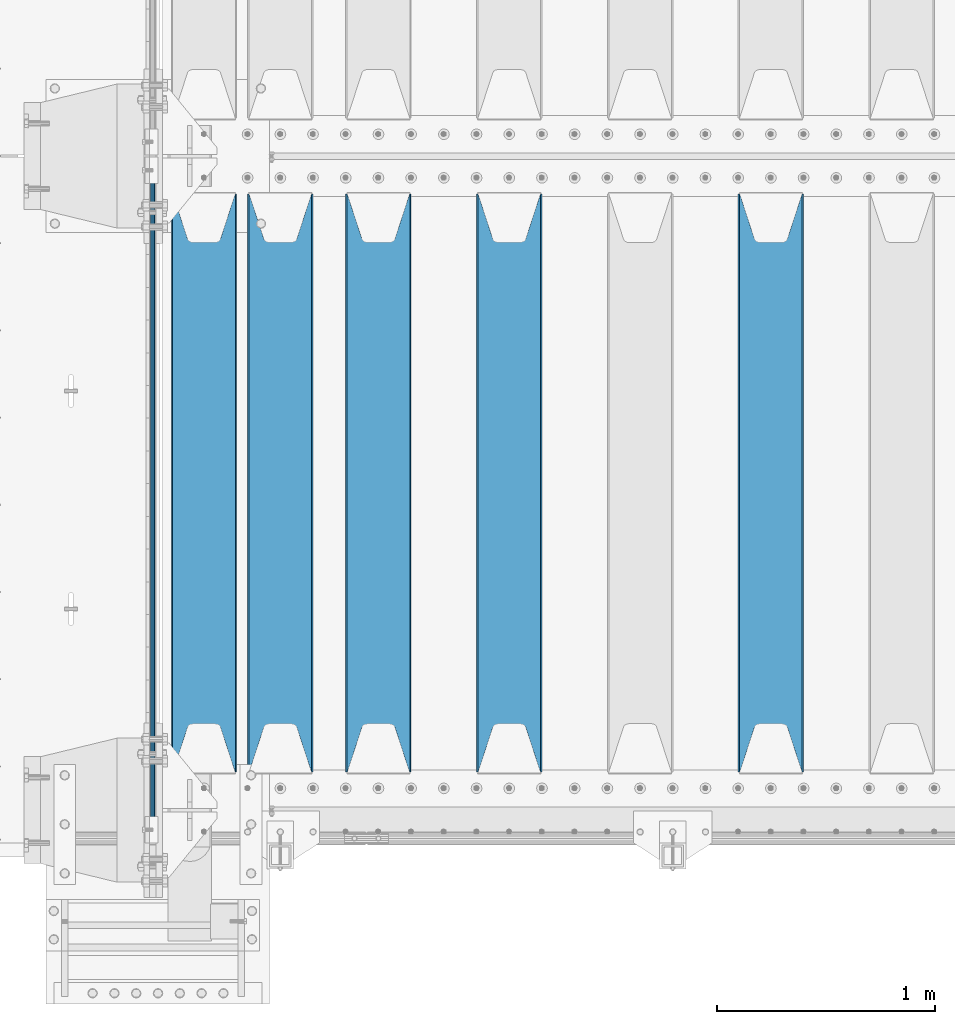
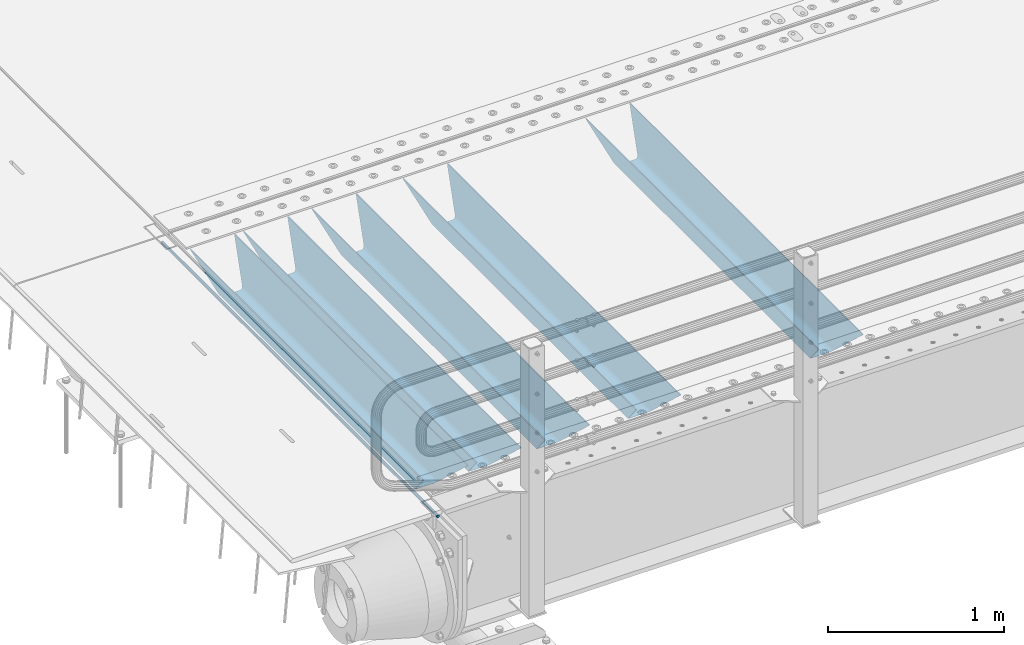
# One storey, part 99 of 240: 6 beams.
"""IFC2X3 building model written with IfcOpenShell, lengths in millimetres."""

from ifc_helpers import new_model, si_unit, frame, origin_with_axes, place, context, subcontext, project, spatial, faceted_brep, material, type_object, element, save


model = new_model("IFC2X3")

# Units and contexts
model_context = context("Model", 3, precision=1e-05, world=origin_with_axes())
body_context = subcontext(model_context, "Body", "Model", "MODEL_VIEW")
ifc_project = project(units=[si_unit("LENGTHUNIT", "METRE", prefix="MILLI"), si_unit("AREAUNIT", "SQUARE_METRE"), si_unit("VOLUMEUNIT", "CUBIC_METRE"), si_unit("MASSUNIT", "GRAM", prefix="KILO"), si_unit("TIMEUNIT", "SECOND"), si_unit("PLANEANGLEUNIT", "RADIAN"), si_unit("SOLIDANGLEUNIT", "STERADIAN"), si_unit("THERMODYNAMICTEMPERATUREUNIT", "DEGREE_CELSIUS"), si_unit("LUMINOUSINTENSITYUNIT", "LUMEN")], contexts=[model_context])

# Site, building, storey
site_placement = place(None, origin_with_axes())
site = spatial("IfcSite", under=ifc_project, at=site_placement, CompositionType="ELEMENT")
building_placement = place(site_placement, origin_with_axes())
building = spatial("IfcBuilding", under=site, at=building_placement, Name="Standard", CompositionType="ELEMENT")
storey_placement = place(building_placement, origin_with_axes())
storey = spatial("IfcBuildingStorey", under=building, at=storey_placement, Name="Undefined", CompositionType="ELEMENT", Elevation=0.0)

# Beams
ifc_material = material(Name="STEEL/S355N")
beam_type_1 = type_object("IfcBeamType", Name="D20", PredefinedType="NOTDEFINED")
beam_1_placement = place(storey_placement, frame((42415.0, 23849.9999999999, -26.0000556136811), z_axis=(0.0, 0.0, 1.0), x_axis=(0.0, 1.0, 0.0)))
element("IfcBeam", 1, at=beam_1_placement, inside=storey, type_object=beam_type_1, material=ifc_material, ObjectType="D20", context=body_context, shape_type="Brep", body=[
    faceted_brep([(0.0, -10.0, 0.0), (0.0, -7.07106781186303, -7.07106781186548), (3144.99999999996, -7.07106781186303, -7.07106781186548), (3144.99999999996, -10.0, 0.0), (0.0, 0.0, -10.0), (3144.99999999996, 0.0, -10.0), (0.0, 7.07106781186303, -7.07106781186547), (3144.99999999996, 7.07106781186303, -7.07106781186547), (0.0, 10.0, 0.0), (3144.99999999996, 10.0, 0.0), (0.0, 7.07106781186303, 7.07106781186548), (3144.99999999996, 7.07106781186303, 7.07106781186548), (0.0, 0.0, 10.0), (3144.99999999996, 0.0, 10.0), (0.0, -7.07106781186303, 7.07106781186548), (3144.99999999996, -7.07106781186303, 7.07106781186548)], [[[0, 1, 2, 3]], [[1, 4, 5, 2]], [[4, 6, 7, 5]], [[6, 8, 9, 7]], [[8, 10, 11, 9]], [[10, 12, 13, 11]], [[12, 14, 15, 13]], [[14, 0, 3, 15]], [[5, 7, 9, 11, 13, 15, 3, 2]], [[14, 12, 10, 8, 6, 4, 1, 0]]]),
])
beam_type_2 = type_object("IfcBeamType", PredefinedType="NOTDEFINED")
beam_2_placement = place(storey_placement, frame((45250.0, 24175.0, -115.0), z_axis=(0.0, 0.0, 1.0), x_axis=(0.0, 1.0, 0.0)))
element("IfcBeam", 2, at=beam_2_placement, inside=storey, type_object=beam_type_2, material=ifc_material, context=body_context, shape_type="Brep", body=[
    faceted_brep([(0.0, 150.0, 115.0), (0.0, 143.690000000002, 115.0), (2650.00000000297, 143.690000000002, 115.0), (2650.00000000297, 150.0, 115.0), (2650.00000000297, 142.059565218406, 110.000000003094), (2650.00000000297, 148.369565218403, 110.000000003094), (2441.90079219209, -80.1103600731149, -98.0992078077845), (2437.7588105432, -77.5672621345584, -102.241189456673), (2434.06523489747, -74.4080125315522, -105.934765102404), (2430.9108609509, -70.7102721255724, -109.089139048974), (2428.37322971128, -66.5649389910031, -111.626770288588), (2426.51472138055, -62.0739139532889, -113.485278619323), (2425.38102192092, -57.3475956567636, -114.618978078955), (2424.99999999987, -52.5021667386536, -115.0), (2424.99999999987, 52.5021667386536, -115.0), (2425.38102192092, 57.3475956567636, -114.618978078955), (2426.51472138055, 62.0739139532889, -113.485278619323), (2428.37322971128, 66.5649389910031, -111.626770288588), (2430.9108609509, 70.7102721255724, -109.089139048974), (2434.06523489747, 74.4080125315522, -105.934765102404), (2437.7588105432, 77.5672621345584, -102.241189456673), (2441.90079219209, 80.1103600731149, -98.0992078077846), (2446.38936140512, 81.9747917625791, -93.6106385947584), (2448.2494850041, 76.2713538057287, -91.7505149957729), (2444.62967112263, 74.76777986261, -95.3703288772456), (2441.28936334127, 72.7168944282894, -98.710636658607), (2438.31067330439, 70.1691124903809, -101.689326695487), (2435.76682334748, 67.1870637758839, -104.233176652398), (2433.72034654134, 63.8440531834931, -106.279653458539), (2432.22154950042, 60.2222587982324, -107.778450499454), (2431.30727574265, 56.4107117849126, -108.692724257221), (2430.99999999987, 52.5031078186876, -109.0), (2430.99999999987, -52.5031078186876, -109.0), (2431.30727574265, -56.4107117849126, -108.692724257221), (2432.22154950042, -60.2222587982324, -107.778450499454), (2433.72034654134, -63.8440531834931, -106.279653458539), (2435.76682334748, -67.1870637758839, -104.233176652398), (2438.31067330439, -70.1691124903809, -101.689326695487), (2441.28936334127, -72.7168944282894, -98.7106366586071), (2444.62967112263, -74.76777986261, -95.3703288772457), (2448.2494850041, -76.2713538057287, -91.7505149957729), (2650.00000000297, -142.059565218406, 110.000000003094), (2650.00000000297, -148.369565218403, 110.000000003094), (2446.38936140512, -81.9747917625791, -93.6106385947584), (2650.00000000297, -143.690000000002, 115.0), (2650.00000000297, -150.0, 115.0), (0.0, -143.690000000002, 115.0), (0.0, -150.0, 115.0), (0.0, -148.369565218258, 110.000000002667), (203.610638597427, -81.9747917625791, -93.6106385947584), (208.09920781045, -80.1103600731149, -98.0992078077845), (212.241189459342, -77.5672621345584, -102.241189456673), (215.93476510507, -74.4080125315522, -105.934765102404), (219.089139051641, -70.7102721255724, -109.089139048974), (221.626770291256, -66.5649389910031, -111.626770288588), (223.485278621989, -62.0739139532889, -113.485278619323), (224.618978081624, -57.3475956567636, -114.618978078955), (225.000000002663, -52.5021667386536, -115.0), (225.000000002663, 52.5021667386536, -115.0), (224.618978081624, 57.3475956567636, -114.618978078955), (223.485278621989, 62.0739139532889, -113.485278619323), (221.626770291256, 66.5649389910031, -111.626770288588), (219.089139051641, 70.7102721255724, -109.089139048974), (215.93476510507, 74.4080125315522, -105.934765102404), (212.241189459342, 77.5672621345584, -102.241189456673), (208.09920781045, 80.1103600731149, -98.0992078077846), (203.610638597427, 81.9747917625791, -93.6106385947584), (0.0, 148.369565218258, 110.000000002667), (0.0, 142.05956521826, 110.000000002667), (201.750514998439, 76.2713538057287, -91.7505149957729), (205.370328879908, 74.76777986261, -95.3703288772456), (208.710636661275, 72.7168944282894, -98.710636658607), (211.689326698153, 70.1691124903809, -101.689326695487), (214.233176655063, 67.1870637758839, -104.233176652398), (216.279653461206, 63.8440531834931, -106.279653458539), (217.778450502123, 60.2222587982324, -107.778450499454), (218.692724259887, 56.4107117849126, -108.692724257221), (219.000000002667, 52.5031078186876, -109.0), (219.000000002667, -52.5031078186876, -109.0), (218.692724259887, -56.4107117849126, -108.692724257221), (217.778450502123, -60.2222587982324, -107.778450499454), (216.279653461206, -63.8440531834931, -106.279653458539), (214.233176655063, -67.1870637758839, -104.233176652398), (211.689326698153, -70.1691124903809, -101.689326695487), (208.710636661275, -72.7168944282894, -98.7106366586071), (205.370328879915, -74.76777986261, -95.3703288772457), (201.750514998439, -76.2713538057287, -91.7505149957729), (0.0, -142.05956521826, 110.000000002667)], [[[0, 1, 2, 3]], [[3, 2, 4, 5]], [[6, 7, 8, 9, 10, 11, 12, 13, 14, 15, 16, 17, 18, 19, 20, 21, 22, 5, 4, 23, 24, 25, 26, 27, 28, 29, 30, 31, 32, 33, 34, 35, 36, 37, 38, 39, 40, 41, 42, 43]], [[44, 45, 42, 41]], [[46, 47, 45, 44]], [[43, 42, 45, 47, 48, 49]], [[6, 43, 49, 50]], [[7, 6, 50, 51]], [[8, 7, 51, 52]], [[9, 8, 52, 53]], [[10, 9, 53, 54]], [[11, 10, 54, 55]], [[12, 11, 55, 56]], [[13, 12, 56, 57]], [[14, 13, 57, 58]], [[15, 14, 58, 59]], [[16, 15, 59, 60]], [[17, 16, 60, 61]], [[18, 17, 61, 62]], [[19, 18, 62, 63]], [[20, 19, 63, 64]], [[21, 20, 64, 65]], [[22, 21, 65, 66]], [[0, 3, 5, 22, 66, 67]], [[1, 0, 67, 68]], [[23, 4, 2, 1, 68, 69]], [[24, 23, 69, 70]], [[25, 24, 70, 71]], [[26, 25, 71, 72]], [[27, 26, 72, 73]], [[28, 27, 73, 74]], [[29, 28, 74, 75]], [[30, 29, 75, 76]], [[31, 30, 76, 77]], [[32, 31, 77, 78]], [[33, 32, 78, 79]], [[34, 33, 79, 80]], [[35, 34, 80, 81]], [[36, 35, 81, 82]], [[37, 36, 82, 83]], [[38, 37, 83, 84]], [[39, 38, 84, 85]], [[40, 39, 85, 86]], [[46, 44, 41, 40, 86, 87]], [[47, 46, 87, 48]], [[86, 85, 84, 83, 82, 81, 80, 79, 78, 77, 76, 75, 74, 73, 72, 71, 70, 69, 68, 67, 66, 65, 64, 63, 62, 61, 60, 59, 58, 57, 56, 55, 54, 53, 52, 51, 50, 49, 48, 87]]]),
])
beam_3_placement = place(storey_placement, frame((44050.0, 24175.0, -115.0), z_axis=(0.0, 0.0, 1.0), x_axis=(0.0, 1.0, 0.0)))
element("IfcBeam", 3, at=beam_3_placement, inside=storey, type_object=beam_type_2, material=ifc_material, context=body_context, shape_type="Brep", body=[
    faceted_brep([(0.0, 150.0, 115.0), (0.0, 143.690000000002, 115.0), (2650.00000000297, 143.690000000002, 115.0), (2650.00000000297, 150.0, 115.0), (2650.00000000297, 142.059565218406, 110.000000003094), (2650.00000000297, 148.369565218403, 110.000000003094), (2441.90079219209, -80.1103600731149, -98.0992078077845), (2437.7588105432, -77.5672621345584, -102.241189456673), (2434.06523489747, -74.4080125315522, -105.934765102404), (2430.9108609509, -70.7102721255724, -109.089139048974), (2428.37322971128, -66.5649389910031, -111.626770288588), (2426.51472138055, -62.0739139532889, -113.485278619323), (2425.38102192092, -57.3475956567636, -114.618978078955), (2424.99999999987, -52.5021667386536, -115.0), (2424.99999999987, 52.5021667386536, -115.0), (2425.38102192092, 57.3475956567636, -114.618978078955), (2426.51472138055, 62.0739139532889, -113.485278619323), (2428.37322971128, 66.5649389910031, -111.626770288588), (2430.9108609509, 70.7102721255724, -109.089139048974), (2434.06523489747, 74.4080125315522, -105.934765102404), (2437.7588105432, 77.5672621345584, -102.241189456673), (2441.90079219209, 80.1103600731149, -98.0992078077846), (2446.38936140512, 81.9747917625791, -93.6106385947584), (2448.2494850041, 76.2713538057287, -91.7505149957729), (2444.62967112263, 74.76777986261, -95.3703288772456), (2441.28936334127, 72.7168944282894, -98.710636658607), (2438.31067330439, 70.1691124903809, -101.689326695487), (2435.76682334748, 67.1870637758839, -104.233176652398), (2433.72034654134, 63.8440531834931, -106.279653458539), (2432.22154950042, 60.2222587982324, -107.778450499454), (2431.30727574265, 56.4107117849126, -108.692724257221), (2430.99999999987, 52.5031078186876, -109.0), (2430.99999999987, -52.5031078186876, -109.0), (2431.30727574265, -56.4107117849126, -108.692724257221), (2432.22154950042, -60.2222587982324, -107.778450499454), (2433.72034654134, -63.8440531834931, -106.279653458539), (2435.76682334748, -67.1870637758839, -104.233176652398), (2438.31067330439, -70.1691124903809, -101.689326695487), (2441.28936334127, -72.7168944282894, -98.7106366586071), (2444.62967112263, -74.76777986261, -95.3703288772457), (2448.2494850041, -76.2713538057287, -91.7505149957729), (2650.00000000297, -142.059565218406, 110.000000003094), (2650.00000000297, -148.369565218403, 110.000000003094), (2446.38936140512, -81.9747917625791, -93.6106385947584), (2650.00000000297, -143.690000000002, 115.0), (2650.00000000297, -150.0, 115.0), (0.0, -143.690000000002, 115.0), (0.0, -150.0, 115.0), (0.0, -148.369565218258, 110.000000002667), (203.610638597427, -81.9747917625791, -93.6106385947584), (208.09920781045, -80.1103600731149, -98.0992078077845), (212.241189459342, -77.5672621345584, -102.241189456673), (215.93476510507, -74.4080125315522, -105.934765102404), (219.089139051641, -70.7102721255724, -109.089139048974), (221.626770291256, -66.5649389910031, -111.626770288588), (223.485278621989, -62.0739139532889, -113.485278619323), (224.618978081624, -57.3475956567636, -114.618978078955), (225.000000002663, -52.5021667386536, -115.0), (225.000000002663, 52.5021667386536, -115.0), (224.618978081624, 57.3475956567636, -114.618978078955), (223.485278621989, 62.0739139532889, -113.485278619323), (221.626770291256, 66.5649389910031, -111.626770288588), (219.089139051641, 70.7102721255724, -109.089139048974), (215.93476510507, 74.4080125315522, -105.934765102404), (212.241189459342, 77.5672621345584, -102.241189456673), (208.09920781045, 80.1103600731149, -98.0992078077846), (203.610638597427, 81.9747917625791, -93.6106385947584), (0.0, 148.369565218258, 110.000000002667), (0.0, 142.05956521826, 110.000000002667), (201.750514998439, 76.2713538057287, -91.7505149957729), (205.370328879908, 74.76777986261, -95.3703288772456), (208.710636661275, 72.7168944282894, -98.710636658607), (211.689326698153, 70.1691124903809, -101.689326695487), (214.233176655063, 67.1870637758839, -104.233176652398), (216.279653461206, 63.8440531834931, -106.279653458539), (217.778450502123, 60.2222587982324, -107.778450499454), (218.692724259887, 56.4107117849126, -108.692724257221), (219.000000002667, 52.5031078186876, -109.0), (219.000000002667, -52.5031078186876, -109.0), (218.692724259887, -56.4107117849126, -108.692724257221), (217.778450502123, -60.2222587982324, -107.778450499454), (216.279653461206, -63.8440531834931, -106.279653458539), (214.233176655063, -67.1870637758839, -104.233176652398), (211.689326698153, -70.1691124903809, -101.689326695487), (208.710636661275, -72.7168944282894, -98.7106366586071), (205.370328879915, -74.76777986261, -95.3703288772457), (201.750514998439, -76.2713538057287, -91.7505149957729), (0.0, -142.05956521826, 110.000000002667)], [[[0, 1, 2, 3]], [[3, 2, 4, 5]], [[6, 7, 8, 9, 10, 11, 12, 13, 14, 15, 16, 17, 18, 19, 20, 21, 22, 5, 4, 23, 24, 25, 26, 27, 28, 29, 30, 31, 32, 33, 34, 35, 36, 37, 38, 39, 40, 41, 42, 43]], [[44, 45, 42, 41]], [[46, 47, 45, 44]], [[43, 42, 45, 47, 48, 49]], [[6, 43, 49, 50]], [[7, 6, 50, 51]], [[8, 7, 51, 52]], [[9, 8, 52, 53]], [[10, 9, 53, 54]], [[11, 10, 54, 55]], [[12, 11, 55, 56]], [[13, 12, 56, 57]], [[14, 13, 57, 58]], [[15, 14, 58, 59]], [[16, 15, 59, 60]], [[17, 16, 60, 61]], [[18, 17, 61, 62]], [[19, 18, 62, 63]], [[20, 19, 63, 64]], [[21, 20, 64, 65]], [[22, 21, 65, 66]], [[0, 3, 5, 22, 66, 67]], [[1, 0, 67, 68]], [[23, 4, 2, 1, 68, 69]], [[24, 23, 69, 70]], [[25, 24, 70, 71]], [[26, 25, 71, 72]], [[27, 26, 72, 73]], [[28, 27, 73, 74]], [[29, 28, 74, 75]], [[30, 29, 75, 76]], [[31, 30, 76, 77]], [[32, 31, 77, 78]], [[33, 32, 78, 79]], [[34, 33, 79, 80]], [[35, 34, 80, 81]], [[36, 35, 81, 82]], [[37, 36, 82, 83]], [[38, 37, 83, 84]], [[39, 38, 84, 85]], [[40, 39, 85, 86]], [[46, 44, 41, 40, 86, 87]], [[47, 46, 87, 48]], [[86, 85, 84, 83, 82, 81, 80, 79, 78, 77, 76, 75, 74, 73, 72, 71, 70, 69, 68, 67, 66, 65, 64, 63, 62, 61, 60, 59, 58, 57, 56, 55, 54, 53, 52, 51, 50, 49, 48, 87]]]),
])
beam_4_placement = place(storey_placement, frame((43450.0, 24175.0, -115.0), z_axis=(0.0, 0.0, 1.0), x_axis=(0.0, 1.0, 0.0)))
element("IfcBeam", 4, at=beam_4_placement, inside=storey, type_object=beam_type_2, material=ifc_material, context=body_context, shape_type="Brep", body=[
    faceted_brep([(0.0, 150.0, 115.0), (0.0, 143.690000000002, 115.0), (2650.00000000297, 143.690000000002, 115.0), (2650.00000000297, 150.0, 115.0), (2650.00000000297, 142.059565218406, 110.000000003094), (2650.00000000297, 148.369565218403, 110.000000003094), (2441.90079219209, -80.1103600731149, -98.0992078077845), (2437.7588105432, -77.5672621345584, -102.241189456673), (2434.06523489747, -74.4080125315522, -105.934765102404), (2430.9108609509, -70.7102721255724, -109.089139048974), (2428.37322971128, -66.5649389910031, -111.626770288588), (2426.51472138055, -62.0739139532889, -113.485278619323), (2425.38102192092, -57.3475956567636, -114.618978078955), (2424.99999999987, -52.5021667386536, -115.0), (2424.99999999987, 52.5021667386536, -115.0), (2425.38102192092, 57.3475956567636, -114.618978078955), (2426.51472138055, 62.0739139532889, -113.485278619323), (2428.37322971128, 66.5649389910031, -111.626770288588), (2430.9108609509, 70.7102721255724, -109.089139048974), (2434.06523489747, 74.4080125315522, -105.934765102404), (2437.7588105432, 77.5672621345584, -102.241189456673), (2441.90079219209, 80.1103600731149, -98.0992078077846), (2446.38936140512, 81.9747917625791, -93.6106385947584), (2448.2494850041, 76.2713538057287, -91.7505149957729), (2444.62967112263, 74.76777986261, -95.3703288772456), (2441.28936334127, 72.7168944282894, -98.710636658607), (2438.31067330439, 70.1691124903809, -101.689326695487), (2435.76682334748, 67.1870637758839, -104.233176652398), (2433.72034654134, 63.8440531834931, -106.279653458539), (2432.22154950042, 60.2222587982324, -107.778450499454), (2431.30727574265, 56.4107117849126, -108.692724257221), (2430.99999999987, 52.5031078186876, -109.0), (2430.99999999987, -52.5031078186876, -109.0), (2431.30727574265, -56.4107117849126, -108.692724257221), (2432.22154950042, -60.2222587982324, -107.778450499454), (2433.72034654134, -63.8440531834931, -106.279653458539), (2435.76682334748, -67.1870637758839, -104.233176652398), (2438.31067330439, -70.1691124903809, -101.689326695487), (2441.28936334127, -72.7168944282894, -98.7106366586071), (2444.62967112263, -74.76777986261, -95.3703288772457), (2448.2494850041, -76.2713538057287, -91.7505149957729), (2650.00000000297, -142.059565218406, 110.000000003094), (2650.00000000297, -148.369565218403, 110.000000003094), (2446.38936140512, -81.9747917625791, -93.6106385947584), (2650.00000000297, -143.690000000002, 115.0), (2650.00000000297, -150.0, 115.0), (0.0, -143.690000000002, 115.0), (0.0, -150.0, 115.0), (0.0, -148.369565218258, 110.000000002667), (203.610638597427, -81.9747917625791, -93.6106385947584), (208.09920781045, -80.1103600731149, -98.0992078077845), (212.241189459342, -77.5672621345584, -102.241189456673), (215.93476510507, -74.4080125315522, -105.934765102404), (219.089139051641, -70.7102721255724, -109.089139048974), (221.626770291256, -66.5649389910031, -111.626770288588), (223.485278621989, -62.0739139532889, -113.485278619323), (224.618978081624, -57.3475956567636, -114.618978078955), (225.000000002663, -52.5021667386536, -115.0), (225.000000002663, 52.5021667386536, -115.0), (224.618978081624, 57.3475956567636, -114.618978078955), (223.485278621989, 62.0739139532889, -113.485278619323), (221.626770291256, 66.5649389910031, -111.626770288588), (219.089139051641, 70.7102721255724, -109.089139048974), (215.93476510507, 74.4080125315522, -105.934765102404), (212.241189459342, 77.5672621345584, -102.241189456673), (208.09920781045, 80.1103600731149, -98.0992078077846), (203.610638597427, 81.9747917625791, -93.6106385947584), (0.0, 148.369565218258, 110.000000002667), (0.0, 142.05956521826, 110.000000002667), (201.750514998439, 76.2713538057287, -91.7505149957729), (205.370328879908, 74.76777986261, -95.3703288772456), (208.710636661275, 72.7168944282894, -98.710636658607), (211.689326698153, 70.1691124903809, -101.689326695487), (214.233176655063, 67.1870637758839, -104.233176652398), (216.279653461206, 63.8440531834931, -106.279653458539), (217.778450502123, 60.2222587982324, -107.778450499454), (218.692724259887, 56.4107117849126, -108.692724257221), (219.000000002667, 52.5031078186876, -109.0), (219.000000002667, -52.5031078186876, -109.0), (218.692724259887, -56.4107117849126, -108.692724257221), (217.778450502123, -60.2222587982324, -107.778450499454), (216.279653461206, -63.8440531834931, -106.279653458539), (214.233176655063, -67.1870637758839, -104.233176652398), (211.689326698153, -70.1691124903809, -101.689326695487), (208.710636661275, -72.7168944282894, -98.7106366586071), (205.370328879915, -74.76777986261, -95.3703288772457), (201.750514998439, -76.2713538057287, -91.7505149957729), (0.0, -142.05956521826, 110.000000002667)], [[[0, 1, 2, 3]], [[3, 2, 4, 5]], [[6, 7, 8, 9, 10, 11, 12, 13, 14, 15, 16, 17, 18, 19, 20, 21, 22, 5, 4, 23, 24, 25, 26, 27, 28, 29, 30, 31, 32, 33, 34, 35, 36, 37, 38, 39, 40, 41, 42, 43]], [[44, 45, 42, 41]], [[46, 47, 45, 44]], [[43, 42, 45, 47, 48, 49]], [[6, 43, 49, 50]], [[7, 6, 50, 51]], [[8, 7, 51, 52]], [[9, 8, 52, 53]], [[10, 9, 53, 54]], [[11, 10, 54, 55]], [[12, 11, 55, 56]], [[13, 12, 56, 57]], [[14, 13, 57, 58]], [[15, 14, 58, 59]], [[16, 15, 59, 60]], [[17, 16, 60, 61]], [[18, 17, 61, 62]], [[19, 18, 62, 63]], [[20, 19, 63, 64]], [[21, 20, 64, 65]], [[22, 21, 65, 66]], [[0, 3, 5, 22, 66, 67]], [[1, 0, 67, 68]], [[23, 4, 2, 1, 68, 69]], [[24, 23, 69, 70]], [[25, 24, 70, 71]], [[26, 25, 71, 72]], [[27, 26, 72, 73]], [[28, 27, 73, 74]], [[29, 28, 74, 75]], [[30, 29, 75, 76]], [[31, 30, 76, 77]], [[32, 31, 77, 78]], [[33, 32, 78, 79]], [[34, 33, 79, 80]], [[35, 34, 80, 81]], [[36, 35, 81, 82]], [[37, 36, 82, 83]], [[38, 37, 83, 84]], [[39, 38, 84, 85]], [[40, 39, 85, 86]], [[46, 44, 41, 40, 86, 87]], [[47, 46, 87, 48]], [[86, 85, 84, 83, 82, 81, 80, 79, 78, 77, 76, 75, 74, 73, 72, 71, 70, 69, 68, 67, 66, 65, 64, 63, 62, 61, 60, 59, 58, 57, 56, 55, 54, 53, 52, 51, 50, 49, 48, 87]]]),
])
beam_5_placement = place(storey_placement, frame((43000.0, 24175.0, -115.0), z_axis=(0.0, 0.0, 1.0), x_axis=(0.0, 1.0, 0.0)))
element("IfcBeam", 5, at=beam_5_placement, inside=storey, type_object=beam_type_2, material=ifc_material, context=body_context, shape_type="Brep", body=[
    faceted_brep([(0.0, 150.0, 115.0), (0.0, 143.690000000002, 115.0), (2650.00000000297, 143.690000000002, 115.0), (2650.00000000297, 150.0, 115.0), (2650.00000000297, 142.059565218406, 110.000000003094), (2650.00000000297, 148.369565218403, 110.000000003094), (2441.90079219209, -80.1103600731149, -98.0992078077845), (2437.7588105432, -77.5672621345584, -102.241189456673), (2434.06523489747, -74.4080125315522, -105.934765102404), (2430.9108609509, -70.7102721255724, -109.089139048974), (2428.37322971128, -66.5649389910031, -111.626770288588), (2426.51472138055, -62.0739139532889, -113.485278619323), (2425.38102192092, -57.3475956567636, -114.618978078955), (2424.99999999987, -52.5021667386536, -115.0), (2424.99999999987, 52.5021667386536, -115.0), (2425.38102192092, 57.3475956567636, -114.618978078955), (2426.51472138055, 62.0739139532889, -113.485278619323), (2428.37322971128, 66.5649389910031, -111.626770288588), (2430.9108609509, 70.7102721255724, -109.089139048974), (2434.06523489747, 74.4080125315522, -105.934765102404), (2437.7588105432, 77.5672621345584, -102.241189456673), (2441.90079219209, 80.1103600731149, -98.0992078077846), (2446.38936140512, 81.9747917625791, -93.6106385947584), (2448.2494850041, 76.2713538057287, -91.7505149957729), (2444.62967112263, 74.76777986261, -95.3703288772456), (2441.28936334127, 72.7168944282894, -98.710636658607), (2438.31067330439, 70.1691124903809, -101.689326695487), (2435.76682334748, 67.1870637758839, -104.233176652398), (2433.72034654134, 63.8440531834931, -106.279653458539), (2432.22154950042, 60.2222587982324, -107.778450499454), (2431.30727574265, 56.4107117849126, -108.692724257221), (2430.99999999987, 52.5031078186876, -109.0), (2430.99999999987, -52.5031078186876, -109.0), (2431.30727574265, -56.4107117849126, -108.692724257221), (2432.22154950042, -60.2222587982324, -107.778450499454), (2433.72034654134, -63.8440531834931, -106.279653458539), (2435.76682334748, -67.1870637758839, -104.233176652398), (2438.31067330439, -70.1691124903809, -101.689326695487), (2441.28936334127, -72.7168944282894, -98.7106366586071), (2444.62967112263, -74.76777986261, -95.3703288772457), (2448.2494850041, -76.2713538057287, -91.7505149957729), (2650.00000000297, -142.059565218406, 110.000000003094), (2650.00000000297, -148.369565218403, 110.000000003094), (2446.38936140512, -81.9747917625791, -93.6106385947584), (2650.00000000297, -143.690000000002, 115.0), (2650.00000000297, -150.0, 115.0), (0.0, -143.690000000002, 115.0), (0.0, -150.0, 115.0), (0.0, -148.369565218258, 110.000000002667), (203.610638597427, -81.9747917625791, -93.6106385947584), (208.09920781045, -80.1103600731149, -98.0992078077845), (212.241189459342, -77.5672621345584, -102.241189456673), (215.93476510507, -74.4080125315522, -105.934765102404), (219.089139051641, -70.7102721255724, -109.089139048974), (221.626770291256, -66.5649389910031, -111.626770288588), (223.485278621989, -62.0739139532889, -113.485278619323), (224.618978081624, -57.3475956567636, -114.618978078955), (225.000000002663, -52.5021667386536, -115.0), (225.000000002663, 52.5021667386536, -115.0), (224.618978081624, 57.3475956567636, -114.618978078955), (223.485278621989, 62.0739139532889, -113.485278619323), (221.626770291256, 66.5649389910031, -111.626770288588), (219.089139051641, 70.7102721255724, -109.089139048974), (215.93476510507, 74.4080125315522, -105.934765102404), (212.241189459342, 77.5672621345584, -102.241189456673), (208.09920781045, 80.1103600731149, -98.0992078077846), (203.610638597427, 81.9747917625791, -93.6106385947584), (0.0, 148.369565218258, 110.000000002667), (0.0, 142.05956521826, 110.000000002667), (201.750514998439, 76.2713538057287, -91.7505149957729), (205.370328879908, 74.76777986261, -95.3703288772456), (208.710636661275, 72.7168944282894, -98.710636658607), (211.689326698153, 70.1691124903809, -101.689326695487), (214.233176655063, 67.1870637758839, -104.233176652398), (216.279653461206, 63.8440531834931, -106.279653458539), (217.778450502123, 60.2222587982324, -107.778450499454), (218.692724259887, 56.4107117849126, -108.692724257221), (219.000000002667, 52.5031078186876, -109.0), (219.000000002667, -52.5031078186876, -109.0), (218.692724259887, -56.4107117849126, -108.692724257221), (217.778450502123, -60.2222587982324, -107.778450499454), (216.279653461206, -63.8440531834931, -106.279653458539), (214.233176655063, -67.1870637758839, -104.233176652398), (211.689326698153, -70.1691124903809, -101.689326695487), (208.710636661275, -72.7168944282894, -98.7106366586071), (205.370328879915, -74.76777986261, -95.3703288772457), (201.750514998439, -76.2713538057287, -91.7505149957729), (0.0, -142.05956521826, 110.000000002667)], [[[0, 1, 2, 3]], [[3, 2, 4, 5]], [[6, 7, 8, 9, 10, 11, 12, 13, 14, 15, 16, 17, 18, 19, 20, 21, 22, 5, 4, 23, 24, 25, 26, 27, 28, 29, 30, 31, 32, 33, 34, 35, 36, 37, 38, 39, 40, 41, 42, 43]], [[44, 45, 42, 41]], [[46, 47, 45, 44]], [[43, 42, 45, 47, 48, 49]], [[6, 43, 49, 50]], [[7, 6, 50, 51]], [[8, 7, 51, 52]], [[9, 8, 52, 53]], [[10, 9, 53, 54]], [[11, 10, 54, 55]], [[12, 11, 55, 56]], [[13, 12, 56, 57]], [[14, 13, 57, 58]], [[15, 14, 58, 59]], [[16, 15, 59, 60]], [[17, 16, 60, 61]], [[18, 17, 61, 62]], [[19, 18, 62, 63]], [[20, 19, 63, 64]], [[21, 20, 64, 65]], [[22, 21, 65, 66]], [[0, 3, 5, 22, 66, 67]], [[1, 0, 67, 68]], [[23, 4, 2, 1, 68, 69]], [[24, 23, 69, 70]], [[25, 24, 70, 71]], [[26, 25, 71, 72]], [[27, 26, 72, 73]], [[28, 27, 73, 74]], [[29, 28, 74, 75]], [[30, 29, 75, 76]], [[31, 30, 76, 77]], [[32, 31, 77, 78]], [[33, 32, 78, 79]], [[34, 33, 79, 80]], [[35, 34, 80, 81]], [[36, 35, 81, 82]], [[37, 36, 82, 83]], [[38, 37, 83, 84]], [[39, 38, 84, 85]], [[40, 39, 85, 86]], [[46, 44, 41, 40, 86, 87]], [[47, 46, 87, 48]], [[86, 85, 84, 83, 82, 81, 80, 79, 78, 77, 76, 75, 74, 73, 72, 71, 70, 69, 68, 67, 66, 65, 64, 63, 62, 61, 60, 59, 58, 57, 56, 55, 54, 53, 52, 51, 50, 49, 48, 87]]]),
])
beam_6_placement = place(storey_placement, frame((42650.0, 24175.0, -115.0), z_axis=(0.0, 0.0, 1.0), x_axis=(0.0, 1.0, 0.0)))
element("IfcBeam", 6, at=beam_6_placement, inside=storey, type_object=beam_type_2, material=ifc_material, context=body_context, shape_type="Brep", body=[
    faceted_brep([(0.0, 150.0, 115.0), (0.0, 143.690000000002, 115.0), (2650.00000000297, 143.690000000002, 115.0), (2650.00000000297, 150.0, 115.0), (2650.00000000297, 142.059565218406, 110.000000003094), (2650.00000000297, 148.369565218403, 110.000000003094), (2441.90079219209, -80.1103600731149, -98.0992078077845), (2437.7588105432, -77.5672621345584, -102.241189456673), (2434.06523489747, -74.4080125315522, -105.934765102404), (2430.9108609509, -70.7102721255724, -109.089139048974), (2428.37322971128, -66.5649389910031, -111.626770288588), (2426.51472138055, -62.0739139532889, -113.485278619323), (2425.38102192092, -57.3475956567636, -114.618978078955), (2424.99999999987, -52.5021667386536, -115.0), (2424.99999999987, 52.5021667386536, -115.0), (2425.38102192092, 57.3475956567636, -114.618978078955), (2426.51472138055, 62.0739139532889, -113.485278619323), (2428.37322971128, 66.5649389910031, -111.626770288588), (2430.9108609509, 70.7102721255724, -109.089139048974), (2434.06523489747, 74.4080125315522, -105.934765102404), (2437.7588105432, 77.5672621345584, -102.241189456673), (2441.90079219209, 80.1103600731149, -98.0992078077846), (2446.38936140512, 81.9747917625791, -93.6106385947584), (2448.2494850041, 76.2713538057287, -91.7505149957729), (2444.62967112263, 74.76777986261, -95.3703288772456), (2441.28936334127, 72.7168944282894, -98.710636658607), (2438.31067330439, 70.1691124903809, -101.689326695487), (2435.76682334748, 67.1870637758839, -104.233176652398), (2433.72034654134, 63.8440531834931, -106.279653458539), (2432.22154950042, 60.2222587982324, -107.778450499454), (2431.30727574265, 56.4107117849126, -108.692724257221), (2430.99999999987, 52.5031078186876, -109.0), (2430.99999999987, -52.5031078186876, -109.0), (2431.30727574265, -56.4107117849126, -108.692724257221), (2432.22154950042, -60.2222587982324, -107.778450499454), (2433.72034654134, -63.8440531834931, -106.279653458539), (2435.76682334748, -67.1870637758839, -104.233176652398), (2438.31067330439, -70.1691124903809, -101.689326695487), (2441.28936334127, -72.7168944282894, -98.7106366586071), (2444.62967112263, -74.76777986261, -95.3703288772457), (2448.2494850041, -76.2713538057287, -91.7505149957729), (2650.00000000297, -142.059565218406, 110.000000003094), (2650.00000000297, -148.369565218403, 110.000000003094), (2446.38936140512, -81.9747917625791, -93.6106385947584), (2650.00000000297, -143.690000000002, 115.0), (2650.00000000297, -150.0, 115.0), (0.0, -143.690000000002, 115.0), (0.0, -150.0, 115.0), (0.0, -148.369565218258, 110.000000002667), (203.610638597427, -81.9747917625791, -93.6106385947584), (208.09920781045, -80.1103600731149, -98.0992078077845), (212.241189459342, -77.5672621345584, -102.241189456673), (215.93476510507, -74.4080125315522, -105.934765102404), (219.089139051641, -70.7102721255724, -109.089139048974), (221.626770291256, -66.5649389910031, -111.626770288588), (223.485278621989, -62.0739139532889, -113.485278619323), (224.618978081624, -57.3475956567636, -114.618978078955), (225.000000002663, -52.5021667386536, -115.0), (225.000000002663, 52.5021667386536, -115.0), (224.618978081624, 57.3475956567636, -114.618978078955), (223.485278621989, 62.0739139532889, -113.485278619323), (221.626770291256, 66.5649389910031, -111.626770288588), (219.089139051641, 70.7102721255724, -109.089139048974), (215.93476510507, 74.4080125315522, -105.934765102404), (212.241189459342, 77.5672621345584, -102.241189456673), (208.09920781045, 80.1103600731149, -98.0992078077846), (203.610638597427, 81.9747917625791, -93.6106385947584), (0.0, 148.369565218258, 110.000000002667), (0.0, 142.05956521826, 110.000000002667), (201.750514998439, 76.2713538057287, -91.7505149957729), (205.370328879908, 74.76777986261, -95.3703288772456), (208.710636661275, 72.7168944282894, -98.710636658607), (211.689326698153, 70.1691124903809, -101.689326695487), (214.233176655063, 67.1870637758839, -104.233176652398), (216.279653461206, 63.8440531834931, -106.279653458539), (217.778450502123, 60.2222587982324, -107.778450499454), (218.692724259887, 56.4107117849126, -108.692724257221), (219.000000002667, 52.5031078186876, -109.0), (219.000000002667, -52.5031078186876, -109.0), (218.692724259887, -56.4107117849126, -108.692724257221), (217.778450502123, -60.2222587982324, -107.778450499454), (216.279653461206, -63.8440531834931, -106.279653458539), (214.233176655063, -67.1870637758839, -104.233176652398), (211.689326698153, -70.1691124903809, -101.689326695487), (208.710636661275, -72.7168944282894, -98.7106366586071), (205.370328879915, -74.76777986261, -95.3703288772457), (201.750514998439, -76.2713538057287, -91.7505149957729), (0.0, -142.05956521826, 110.000000002667)], [[[0, 1, 2, 3]], [[3, 2, 4, 5]], [[6, 7, 8, 9, 10, 11, 12, 13, 14, 15, 16, 17, 18, 19, 20, 21, 22, 5, 4, 23, 24, 25, 26, 27, 28, 29, 30, 31, 32, 33, 34, 35, 36, 37, 38, 39, 40, 41, 42, 43]], [[44, 45, 42, 41]], [[46, 47, 45, 44]], [[43, 42, 45, 47, 48, 49]], [[6, 43, 49, 50]], [[7, 6, 50, 51]], [[8, 7, 51, 52]], [[9, 8, 52, 53]], [[10, 9, 53, 54]], [[11, 10, 54, 55]], [[12, 11, 55, 56]], [[13, 12, 56, 57]], [[14, 13, 57, 58]], [[15, 14, 58, 59]], [[16, 15, 59, 60]], [[17, 16, 60, 61]], [[18, 17, 61, 62]], [[19, 18, 62, 63]], [[20, 19, 63, 64]], [[21, 20, 64, 65]], [[22, 21, 65, 66]], [[0, 3, 5, 22, 66, 67]], [[1, 0, 67, 68]], [[23, 4, 2, 1, 68, 69]], [[24, 23, 69, 70]], [[25, 24, 70, 71]], [[26, 25, 71, 72]], [[27, 26, 72, 73]], [[28, 27, 73, 74]], [[29, 28, 74, 75]], [[30, 29, 75, 76]], [[31, 30, 76, 77]], [[32, 31, 77, 78]], [[33, 32, 78, 79]], [[34, 33, 79, 80]], [[35, 34, 80, 81]], [[36, 35, 81, 82]], [[37, 36, 82, 83]], [[38, 37, 83, 84]], [[39, 38, 84, 85]], [[40, 39, 85, 86]], [[46, 44, 41, 40, 86, 87]], [[47, 46, 87, 48]], [[86, 85, 84, 83, 82, 81, 80, 79, 78, 77, 76, 75, 74, 73, 72, 71, 70, 69, 68, 67, 66, 65, 64, 63, 62, 61, 60, 59, 58, 57, 56, 55, 54, 53, 52, 51, 50, 49, 48, 87]]]),
])

save(model, "model.ifc")
